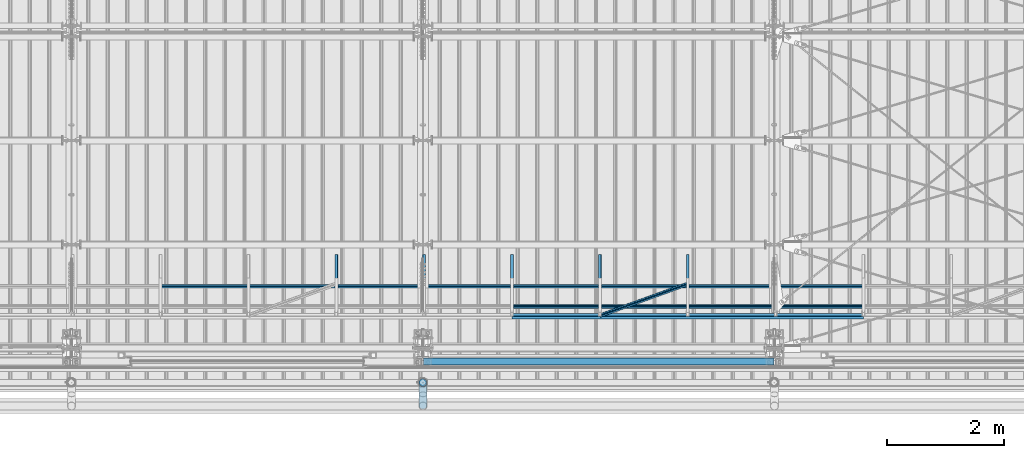
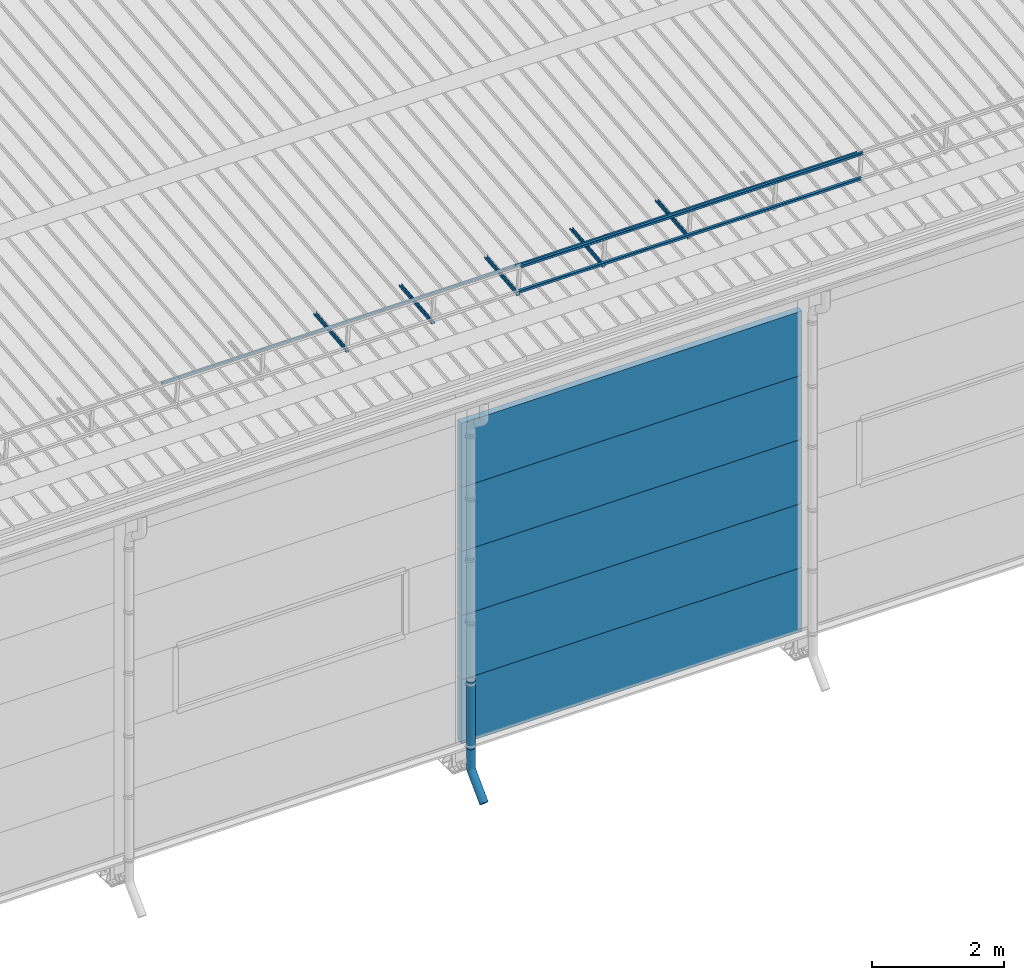
# One storey, part 64 of 709: 18 beams, 18 elements without a shape of their own.
"""IFC4 building model written with IfcOpenShell, lengths in millimetres."""

import ifcopenshell
import ifcopenshell.guid

model = None  # the IFC model being written
_history = None  # IfcOwnerHistory: only IFC2X3 demands one
_inside = {}  # id of a spatial element -> (the spatial element, [elements in it])
_under = {}  # id of a project, library or spatial element -> (it, [spatial elements below it])
_declared = {}  # id of a project -> (the project, [libraries it declares])
_typed = {}  # id of a type object -> (the type object, [elements of that type])
_made_of = {}  # id of a material, layer set ... -> (it, [elements and type objects made of it])


def new_model(schema):
    """Start an empty IFC model of exactly this schema.

    Asked for "IFC4X3", IfcOpenShell would pick the latest addendum, in which some entities
    have other attributes; the version numbers below select the first issue.
    IFC2X3 requires an IfcOwnerHistory on every rooted entity: one is made here for all.
    """
    global model, _history
    if schema == "IFC4X3":
        model = ifcopenshell.file(schema_version=(4, 3, 0, 0))
    else:
        model = ifcopenshell.file(schema=schema)
    _inside.clear()
    _under.clear()
    _declared.clear()
    _typed.clear()
    _made_of.clear()
    _history = None
    if model.schema == "IFC2X3":
        org = make("IfcOrganization", Name="unknown")
        user = make(
            "IfcPersonAndOrganization",
            ThePerson=make("IfcPerson", FamilyName="unknown"),
            TheOrganization=org,
        )
        app = make(
            "IfcApplication",
            ApplicationDeveloper=org,
            Version="unknown",
            ApplicationFullName="unknown",
            ApplicationIdentifier="unknown",
        )
        _history = make(
            "IfcOwnerHistory",
            OwningUser=user,
            OwningApplication=app,
            ChangeAction="ADDED",
            CreationDate=0,
        )
    return model


def make(cls, **values):
    """One entity of the class cls with the attributes given. An attribute that is None is left unset."""
    return model.create_entity(
        cls, **{name: value for name, value in values.items() if value is not None}
    )


def entity(cls, *values):
    """Any entity or typed value of the class cls, its attributes in the order of the schema. None: left unset."""
    e = model.create_entity(cls)
    for i, value in enumerate(values):
        if value is not None:
            e[i] = value
    return e


def rooted(cls, **values):
    """An entity with a GlobalId (a new one), such as an element, a storey or a relation."""
    return make(cls, GlobalId=ifcopenshell.guid.new(), OwnerHistory=_history, **values)


def si_unit(unit_type, name, prefix=None):
    """IfcSIUnit, for example si_unit("LENGTHUNIT", "METRE", prefix="MILLI")."""
    return make("IfcSIUnit", UnitType=unit_type, Prefix=prefix, Name=name)


def assignment(units):
    """IfcUnitAssignment: the units of a project."""
    return None if units is None else make("IfcUnitAssignment", Units=units)


def point(xyz):
    """IfcCartesianPoint."""
    return None if xyz is None else make("IfcCartesianPoint", Coordinates=xyz)


def direction(xyz):
    """IfcDirection."""
    return None if xyz is None else make("IfcDirection", DirectionRatios=xyz)


def frame(location, z_axis=None, x_axis=None):
    """IfcAxis2Placement3D, a coordinate frame: its origin and axes. An axis left out is left unset."""
    return make(
        "IfcAxis2Placement3D",
        Location=point(location),
        Axis=direction(z_axis),
        RefDirection=direction(x_axis),
    )


def origin_with_axes():
    """The frame at (0, 0, 0) with the z axis (0, 0, 1) and the x axis (1, 0, 0) written out."""
    return frame((0.0, 0.0, 0.0), z_axis=(0.0, 0.0, 1.0), x_axis=(1.0, 0.0, 0.0))


def place(relative_to, where):
    """IfcLocalPlacement: puts the frame where relative to a parent placement (None: the world)."""
    return make(
        "IfcLocalPlacement", PlacementRelTo=relative_to, RelativePlacement=where
    )


def context(
    kind, dimensions, precision=None, world=None, true_north=None, identifier=None
):
    """IfcGeometricRepresentationContext, for example the 3D "Model" context."""
    return make(
        "IfcGeometricRepresentationContext",
        ContextIdentifier=identifier,
        ContextType=kind,
        CoordinateSpaceDimension=dimensions,
        Precision=precision,
        WorldCoordinateSystem=world,
        TrueNorth=true_north,
    )


def subcontext(parent, identifier, kind, view, scale=None):
    """IfcGeometricRepresentationSubContext, for example "Body" below "Model"."""
    return make(
        "IfcGeometricRepresentationSubContext",
        ContextIdentifier=identifier,
        ContextType=kind,
        ParentContext=parent,
        TargetScale=scale,
        TargetView=view,
    )


def project(units=None, contexts=None):
    """IfcProject with its units and contexts."""
    return rooted(
        "IfcProject",
        Name="project",
        RepresentationContexts=contexts,
        UnitsInContext=assignment(units),
    )


def spatial(cls, under=None, at=None, **own):
    """A site, building, storey or space (cls), placed at a placement, below another one or the project."""
    s = rooted(cls, ObjectPlacement=at, **own)
    if under is not None:
        _under.setdefault(under.id(), (under, []))[1].append(s)
    return s


def point_list(points):
    """IfcCartesianPointList2D or 3D."""
    cls = (
        "IfcCartesianPointList2D" if len(points[0]) == 2 else "IfcCartesianPointList3D"
    )
    return make(cls, CoordList=points)


def line(*indices):
    """IfcLineIndex: a straight run through numbered points of an indexed curve."""
    return model.create_entity("IfcLineIndex", indices)


def indexed_curve(points, segments=None, self_intersect=None):
    """IfcIndexedPolyCurve: lines and arcs through numbered points (the first is 1)."""
    return make(
        "IfcIndexedPolyCurve",
        Points=point_list(points),
        Segments=segments,
        SelfIntersect=self_intersect,
    )


def outline(outer, holes=None, kind="AREA"):
    """IfcArbitraryClosedProfileDef: a profile drawn as a closed curve; with holes, ...WithVoids."""
    if holes is None:
        return make("IfcArbitraryClosedProfileDef", ProfileType=kind, OuterCurve=outer)
    return make(
        "IfcArbitraryProfileDefWithVoids",
        ProfileType=kind,
        OuterCurve=outer,
        InnerCurves=holes,
    )


def extrude(swept, where, along, depth):
    """IfcExtrudedAreaSolid: the profile swept, set in the frame where, extruded along a direction by depth."""
    return make(
        "IfcExtrudedAreaSolid",
        SweptArea=swept,
        Position=where,
        ExtrudedDirection=direction(along),
        Depth=depth,
    )


def shape(context_of_items, identifier, shape_type, items):
    """IfcShapeRepresentation: the items that make up one representation, for example the "Body"."""
    return make(
        "IfcShapeRepresentation",
        ContextOfItems=context_of_items,
        RepresentationIdentifier=identifier,
        RepresentationType=shape_type,
        Items=items,
    )


def material(Name=None, Category=None):
    """IfcMaterial."""
    return make("IfcMaterial", Name=Name, Category=Category)


def made_of(thing, what):
    """Note that an element or type object is made of a material, layer set ...; save() writes the relation."""
    if what is not None:
        _made_of.setdefault(what.id(), (what, []))[1].append(thing)
    return thing


def element(
    cls,
    number,
    at=None,
    inside=None,
    cuts=None,
    type_object=None,
    material=None,
    context=None,
    identifier="Body",
    shape_type=None,
    held_by="IfcProductDefinitionShape",
    body=None,
    shapes=None,
    **own,
):
    """One element of the class cls, such as IfcWall. Its Tag is "e" and its number.

    at: its placement. inside: the storey or other place that contains it. cuts: it is an
    opening in that element (IfcRelVoidsElement). A single representation is given by context,
    identifier, shape_type and body (its items); several are given by shapes. held_by: the class
    of the entity that holds the representations. save() writes the other relations.
    """
    e = rooted(cls, Tag="e%d" % number, ObjectPlacement=at, **own)
    if body is not None:
        shapes = [shape(context, identifier, shape_type, body)]
    if shapes is not None:
        e.Representation = make(held_by, Representations=shapes)
    if inside is not None:
        _inside.setdefault(inside.id(), (inside, []))[1].append(e)
    if cuts is not None:
        rooted(
            "IfcRelVoidsElement", RelatingBuildingElement=cuts, RelatedOpeningElement=e
        )
    if type_object is not None:
        _typed.setdefault(type_object.id(), (type_object, []))[1].append(e)
    return made_of(e, material)


def aggregate(whole, parts):
    """IfcRelAggregates: a whole, such as a stair, and the parts it consists of."""
    return rooted("IfcRelAggregates", RelatingObject=whole, RelatedObjects=parts)


def save(model, path):
    """Write the relations noted so far, then the file.

    IfcRelAggregates (storeys below a building ...), IfcRelContainedInSpatialStructure (elements
    in a storey), IfcRelDefinesByType, IfcRelAssociatesMaterial and IfcRelDeclares: one each for
    every whole, place, type object, material and project.
    """
    for whole, parts in _under.values():
        aggregate(whole, parts)
    for where, things in _inside.values():
        rooted(
            "IfcRelContainedInSpatialStructure",
            RelatedElements=things,
            RelatingStructure=where,
        )
    for kind, things in _typed.values():
        rooted("IfcRelDefinesByType", RelatedObjects=things, RelatingType=kind)
    for what, things in _made_of.values():
        rooted("IfcRelAssociatesMaterial", RelatedObjects=things, RelatingMaterial=what)
    for by, libraries in _declared.values():
        rooted("IfcRelDeclares", RelatingContext=by, RelatedDefinitions=libraries)
    model.write(path)


model = new_model("IFC4")

# Units and contexts
model_context = context("Model", 3, precision=0.2, world=origin_with_axes(), true_north=direction((0.0, 1.0)))
body_context = subcontext(model_context, "Body", "Model", "MODEL_VIEW")
ifc_project = project(units=[si_unit("LENGTHUNIT", "METRE", prefix="MILLI"), si_unit("AREAUNIT", "SQUARE_METRE"), si_unit("VOLUMEUNIT", "CUBIC_METRE"), si_unit("MASSUNIT", "GRAM", prefix="KILO"), si_unit("TIMEUNIT", "SECOND"), si_unit("PLANEANGLEUNIT", "RADIAN"), si_unit("SOLIDANGLEUNIT", "STERADIAN"), si_unit("THERMODYNAMICTEMPERATUREUNIT", "DEGREE_CELSIUS"), si_unit("LUMINOUSINTENSITYUNIT", "LUMEN")], contexts=[model_context])

# Site, building, storey
site_placement = place(None, origin_with_axes())
site = spatial("IfcSite", under=ifc_project, at=site_placement, CompositionType="ELEMENT")
building_placement = place(site_placement, origin_with_axes())
building = spatial("IfcBuilding", under=site, at=building_placement, Name="Undefined", CompositionType="ELEMENT")
storey_placement = place(building_placement, origin_with_axes())
storey = spatial("IfcBuildingStorey", under=building, at=storey_placement, Name="Undefined", CompositionType="ELEMENT", Elevation=0.0)

# Assembly, beam
assembly_1_placement = place(storey_placement, frame((32520.0, 768.92298, 7577.16191), z_axis=(0.0, -0.099503719, 0.9950371902), x_axis=(0.0, 0.9950371902, 0.099503719)))
assembly_1 = element("IfcElementAssembly", 1, at=assembly_1_placement, inside=storey)
ifc_material_1 = material(Name="Steel_Undefined", Category="STEEL")
beam_1_placement = place(assembly_1_placement, origin_with_axes())
beam_1 = element("IfcBeam", 2, at=beam_1_placement, material=ifc_material_1, ObjectType="601", context=body_context, shape_type="SolidModel", body=[
    extrude(outline(indexed_curve([(-20.0, -25.0), (20.0, -25.0), (20.0, -22.5), (-17.5, -22.5), (-17.5, 22.5), (20.0, 22.5), (20.0, 25.0), (-20.0, 25.0)], segments=[line(1, 2, 3, 4, 5, 6, 7, 8, 1)])), frame((0.0, 0.0, 0.0), z_axis=(-1.0, 0.0, 0.0), x_axis=(0.0, 0.0, 1.0)), (0.0, 0.0, -1.0), 1000.0),
])
aggregate(assembly_1, [beam_1])

assembly_2_placement = place(storey_placement, frame((34020.0, 768.92298, 7577.16191), z_axis=(0.0, -0.099503719, 0.9950371902), x_axis=(0.0, 0.9950371902, 0.099503719)))
assembly_2 = element("IfcElementAssembly", 3, at=assembly_2_placement, inside=storey)
beam_2_placement = place(assembly_2_placement, origin_with_axes())
beam_2 = element("IfcBeam", 4, at=beam_2_placement, material=ifc_material_1, ObjectType="601", context=body_context, shape_type="SolidModel", body=[
    extrude(outline(indexed_curve([(-20.0, -25.0), (20.0, -25.0), (20.0, -22.5), (-17.5, -22.5), (-17.5, 22.5), (20.0, 22.5), (20.0, 25.0), (-20.0, 25.0)], segments=[line(1, 2, 3, 4, 5, 6, 7, 8, 1)])), frame((0.0, 0.0, 0.0), z_axis=(-1.0, 0.0, 0.0), x_axis=(0.0, 0.0, 1.0)), (0.0, 0.0, -1.0), 1000.0),
])
aggregate(assembly_2, [beam_2])

assembly_3_placement = place(storey_placement, frame((29520.0, 1225.80867, 7759.0901), z_axis=(0.0, 0.6332377902, 0.7739572992), x_axis=(1.0, 0.0, 0.0)))
assembly_3 = element("IfcElementAssembly", 5, at=assembly_3_placement, inside=storey)
beam_3_placement = place(assembly_3_placement, origin_with_axes())
beam_3 = element("IfcBeam", 6, at=beam_3_placement, material=ifc_material_1, ObjectType="606", context=body_context, shape_type="SolidModel", body=[
    extrude(outline(indexed_curve([(-20.0, -25.0), (20.0, -25.0), (20.0, -22.5), (-17.5, -22.5), (-17.5, 22.5), (20.0, 22.5), (20.0, 25.0), (-20.0, 25.0)], segments=[line(1, 2, 3, 4, 5, 6, 7, 8, 1)])), frame((0.0, 0.0, 0.0), z_axis=(-1.0, 0.0, 0.0), x_axis=(0.0, 0.0, 1.0)), (0.0, 0.0, -1.0), 6000.0),
])
aggregate(assembly_3, [beam_3])

assembly_4_placement = place(storey_placement, frame((35520.0, 768.92298, 7577.16191), z_axis=(0.0, -0.099503719, 0.9950371902), x_axis=(0.0, 0.9950371902, 0.099503719)))
assembly_4 = element("IfcElementAssembly", 7, at=assembly_4_placement, inside=storey)
beam_4_placement = place(assembly_4_placement, origin_with_axes())
beam_4 = element("IfcBeam", 8, at=beam_4_placement, material=ifc_material_1, ObjectType="601", context=body_context, shape_type="SolidModel", body=[
    extrude(outline(indexed_curve([(-20.0, -25.0), (20.0, -25.0), (20.0, -22.5), (-17.5, -22.5), (-17.5, 22.5), (20.0, 22.5), (20.0, 25.0), (-20.0, 25.0)], segments=[line(1, 2, 3, 4, 5, 6, 7, 8, 1)])), frame((0.0, 0.0, 0.0), z_axis=(-1.0, 0.0, 0.0), x_axis=(0.0, 0.0, 1.0)), (0.0, 0.0, -1.0), 1000.0),
])
aggregate(assembly_4, [beam_4])

assembly_5_placement = place(storey_placement, frame((37020.0, 768.92298, 7577.16191), z_axis=(0.0, -0.099503719, 0.9950371902), x_axis=(0.0, 0.9950371902, 0.099503719)))
assembly_5 = element("IfcElementAssembly", 9, at=assembly_5_placement, inside=storey)
beam_5_placement = place(assembly_5_placement, origin_with_axes())
beam_5 = element("IfcBeam", 10, at=beam_5_placement, material=ifc_material_1, ObjectType="601", context=body_context, shape_type="SolidModel", body=[
    extrude(outline(indexed_curve([(-20.0, -25.0), (20.0, -25.0), (20.0, -22.5), (-17.5, -22.5), (-17.5, 22.5), (20.0, 22.5), (20.0, 25.0), (-20.0, 25.0)], segments=[line(1, 2, 3, 4, 5, 6, 7, 8, 1)])), frame((0.0, 0.0, 0.0), z_axis=(-1.0, 0.0, 0.0), x_axis=(0.0, 0.0, 1.0)), (0.0, 0.0, -1.0), 1000.0),
])
aggregate(assembly_5, [beam_5])

assembly_6_placement = place(storey_placement, frame((38520.0, 768.92298, 7577.16191), z_axis=(0.0, -0.099503719, 0.9950371902), x_axis=(0.0, 0.9950371902, 0.099503719)))
assembly_6 = element("IfcElementAssembly", 11, at=assembly_6_placement, inside=storey)
beam_6_placement = place(assembly_6_placement, origin_with_axes())
beam_6 = element("IfcBeam", 12, at=beam_6_placement, material=ifc_material_1, ObjectType="601", context=body_context, shape_type="SolidModel", body=[
    extrude(outline(indexed_curve([(-20.0, -25.0), (20.0, -25.0), (20.0, -22.5), (-17.5, -22.5), (-17.5, 22.5), (20.0, 22.5), (20.0, 25.0), (-20.0, 25.0)], segments=[line(1, 2, 3, 4, 5, 6, 7, 8, 1)])), frame((0.0, 0.0, 0.0), z_axis=(-1.0, 0.0, 0.0), x_axis=(0.0, 0.0, 1.0)), (0.0, 0.0, -1.0), 1000.0),
])
aggregate(assembly_6, [beam_6])

assembly_7_placement = place(storey_placement, frame((35520.0, 691.31008, 8152.29341), z_axis=(0.0, -0.9950371902, -0.099503719), x_axis=(1.0, 0.0, 0.0)))
assembly_7 = element("IfcElementAssembly", 13, at=assembly_7_placement, inside=storey)
beam_7_placement = place(assembly_7_placement, origin_with_axes())
beam_7 = element("IfcBeam", 14, at=beam_7_placement, material=ifc_material_1, ObjectType="606", context=body_context, shape_type="SolidModel", body=[
    extrude(outline(indexed_curve([(-20.0, -25.0), (20.0, -25.0), (20.0, -22.5), (-17.5, -22.5), (-17.5, 22.5), (20.0, 22.5), (20.0, 25.0), (-20.0, 25.0)], segments=[line(1, 2, 3, 4, 5, 6, 7, 8, 1)])), frame((0.0, 0.0, 0.0), z_axis=(-1.0, 0.0, 0.0), x_axis=(0.0, 0.0, 1.0)), (0.0, 0.0, -1.0), 6000.0),
])
aggregate(assembly_7, [beam_7])

assembly_8_placement = place(storey_placement, frame((35520.0, 741.06194, 7654.77481), z_axis=(0.0, -0.9950371902, -0.099503719), x_axis=(1.0, 0.0, 0.0)))
assembly_8 = element("IfcElementAssembly", 15, at=assembly_8_placement, inside=storey)
beam_8_placement = place(assembly_8_placement, origin_with_axes())
beam_8 = element("IfcBeam", 16, at=beam_8_placement, material=ifc_material_1, ObjectType="606", context=body_context, shape_type="SolidModel", body=[
    extrude(outline(indexed_curve([(-20.0, -25.0), (20.0, -25.0), (20.0, -22.5), (-17.5, -22.5), (-17.5, 22.5), (20.0, 22.5), (20.0, 25.0), (-20.0, 25.0)], segments=[line(1, 2, 3, 4, 5, 6, 7, 8, 1)])), frame((0.0, 0.0, 0.0), z_axis=(-1.0, 0.0, 0.0), x_axis=(0.0, 0.0, 1.0)), (0.0, 0.0, -1.0), 6000.0),
])
aggregate(assembly_8, [beam_8])

assembly_9_placement = place(storey_placement, frame((35520.0, 878.66704, 8043.11507), z_axis=(0.0, 0.6332377902, 0.7739572992), x_axis=(1.0, 0.0, 0.0)))
assembly_9 = element("IfcElementAssembly", 17, at=assembly_9_placement, inside=storey)
beam_9_placement = place(assembly_9_placement, origin_with_axes())
beam_9 = element("IfcBeam", 18, at=beam_9_placement, material=ifc_material_1, ObjectType="606", context=body_context, shape_type="SolidModel", body=[
    extrude(outline(indexed_curve([(-20.0, -25.0), (20.0, -25.0), (20.0, -22.5), (-17.5, -22.5), (-17.5, 22.5), (20.0, 22.5), (20.0, 25.0), (-20.0, 25.0)], segments=[line(1, 2, 3, 4, 5, 6, 7, 8, 1)])), frame((0.0, 0.0, 0.0), z_axis=(-1.0, 0.0, 0.0), x_axis=(0.0, 0.0, 1.0)), (0.0, 0.0, -1.0), 6000.0),
])
aggregate(assembly_9, [beam_9])

assembly_10_placement = place(storey_placement, frame((35520.0, 1225.80867, 7759.0901), z_axis=(0.0, 0.6332377902, 0.7739572992), x_axis=(1.0, 0.0, 0.0)))
assembly_10 = element("IfcElementAssembly", 19, at=assembly_10_placement, inside=storey)
beam_10_placement = place(assembly_10_placement, origin_with_axes())
beam_10 = element("IfcBeam", 20, at=beam_10_placement, material=ifc_material_1, ObjectType="606", context=body_context, shape_type="SolidModel", body=[
    extrude(outline(indexed_curve([(-20.0, -25.0), (20.0, -25.0), (20.0, -22.5), (-17.5, -22.5), (-17.5, 22.5), (20.0, 22.5), (20.0, 25.0), (-20.0, 25.0)], segments=[line(1, 2, 3, 4, 5, 6, 7, 8, 1)])), frame((0.0, 0.0, 0.0), z_axis=(-1.0, 0.0, 0.0), x_axis=(0.0, 0.0, 1.0)), (0.0, 0.0, -1.0), 6000.0),
])
aggregate(assembly_10, [beam_10])

assembly_11_placement = place(storey_placement, frame((37020.0, 723.87558, 8169.76263), z_axis=(0.0, 0.6332377902, 0.7739572992), x_axis=(0.9061831398, 0.3272952929, -0.2677870579)))
assembly_11 = element("IfcElementAssembly", 21, at=assembly_11_placement, inside=storey)
beam_11_placement = place(assembly_11_placement, origin_with_axes())
beam_11 = element("IfcBeam", 22, at=beam_11_placement, material=ifc_material_1, ObjectType="605", context=body_context, shape_type="SolidModel", body=[
    extrude(outline(indexed_curve([(-20.0, -25.0), (20.0, -25.0), (20.0, -22.5), (-17.5, -22.5), (-17.5, 22.5), (20.0, 22.5), (20.0, 25.0), (-20.0, 25.0)], segments=[line(1, 2, 3, 4, 5, 6, 7, 8, 1)])), frame((0.0, 0.0, 0.0), z_axis=(-1.0, 0.0, 0.0), x_axis=(0.0, 0.0, 1.0)), (0.0, 0.0, -1.0), 1655.29454),
])
aggregate(assembly_11, [beam_11])

assembly_12_placement = place(storey_placement, frame((34010.0, -60.0, 895.0), z_axis=(0.0, 0.0, -1.0), x_axis=(1.0, 0.0, 0.0)))
assembly_12 = element("IfcElementAssembly", 23, at=assembly_12_placement, inside=storey)
ifc_material_2 = material(Name="Insulation", Category="Insulation")
beam_12_placement = place(assembly_12_placement, origin_with_axes())
beam_12 = element("IfcBeam", 24, at=beam_12_placement, material=ifc_material_2, ObjectType="P-107", context=body_context, shape_type="SolidModel", body=[
    extrude(outline(indexed_curve([(-595.0, -60.0), (595.0, -60.0), (595.0, 60.0), (-595.0, 60.0)], segments=[line(1, 2, 3, 4, 1)])), frame((0.0, 0.0, 0.0), z_axis=(-1.0, 0.0, 0.0), x_axis=(0.0, 0.0, 1.0)), (0.0, 0.0, -1.0), 5980.0),
])
aggregate(assembly_12, [beam_12])

assembly_13_placement = place(storey_placement, frame((34010.0, -60.0, 2085.0), z_axis=(0.0, 0.0, -1.0), x_axis=(1.0, 0.0, 0.0)))
assembly_13 = element("IfcElementAssembly", 25, at=assembly_13_placement, inside=storey)
beam_13_placement = place(assembly_13_placement, origin_with_axes())
beam_13 = element("IfcBeam", 26, at=beam_13_placement, material=ifc_material_2, ObjectType="P-107", context=body_context, shape_type="SolidModel", body=[
    extrude(outline(indexed_curve([(-595.0, -60.0), (595.0, -60.0), (595.0, 60.0), (-595.0, 60.0)], segments=[line(1, 2, 3, 4, 1)])), frame((0.0, 0.0, 0.0), z_axis=(-1.0, 0.0, 0.0), x_axis=(0.0, 0.0, 1.0)), (0.0, 0.0, -1.0), 5980.0),
])
aggregate(assembly_13, [beam_13])

assembly_14_placement = place(storey_placement, frame((34010.0, -60.0, 3275.0), z_axis=(0.0, 0.0, -1.0), x_axis=(1.0, 0.0, 0.0)))
assembly_14 = element("IfcElementAssembly", 27, at=assembly_14_placement, inside=storey)
beam_14_placement = place(assembly_14_placement, origin_with_axes())
beam_14 = element("IfcBeam", 28, at=beam_14_placement, material=ifc_material_2, ObjectType="P-107", context=body_context, shape_type="SolidModel", body=[
    extrude(outline(indexed_curve([(-595.0, -60.0), (595.0, -60.0), (595.0, 60.0), (-595.0, 60.0)], segments=[line(1, 2, 3, 4, 1)])), frame((0.0, 0.0, 0.0), z_axis=(-1.0, 0.0, 0.0), x_axis=(0.0, 0.0, 1.0)), (0.0, 0.0, -1.0), 5980.0),
])
aggregate(assembly_14, [beam_14])

assembly_15_placement = place(storey_placement, frame((34010.0, -60.0, 4465.0), z_axis=(0.0, 0.0, -1.0), x_axis=(1.0, 0.0, 0.0)))
assembly_15 = element("IfcElementAssembly", 29, at=assembly_15_placement, inside=storey)
beam_15_placement = place(assembly_15_placement, origin_with_axes())
beam_15 = element("IfcBeam", 30, at=beam_15_placement, material=ifc_material_2, ObjectType="P-107", context=body_context, shape_type="SolidModel", body=[
    extrude(outline(indexed_curve([(-595.0, -60.0), (595.0, -60.0), (595.0, 60.0), (-595.0, 60.0)], segments=[line(1, 2, 3, 4, 1)])), frame((0.0, 0.0, 0.0), z_axis=(-1.0, 0.0, 0.0), x_axis=(0.0, 0.0, 1.0)), (0.0, 0.0, -1.0), 5980.0),
])
aggregate(assembly_15, [beam_15])

assembly_16_placement = place(storey_placement, frame((34010.0, -60.0, 5655.0), z_axis=(0.0, 0.0, -1.0), x_axis=(1.0, 0.0, 0.0)))
assembly_16 = element("IfcElementAssembly", 31, at=assembly_16_placement, inside=storey)
beam_16_placement = place(assembly_16_placement, origin_with_axes())
beam_16 = element("IfcBeam", 32, at=beam_16_placement, material=ifc_material_2, ObjectType="P-107", context=body_context, shape_type="SolidModel", body=[
    extrude(outline(indexed_curve([(-595.0, -60.0), (595.0, -60.0), (595.0, 60.0), (-595.0, 60.0)], segments=[line(1, 2, 3, 4, 1)])), frame((0.0, 0.0, 0.0), z_axis=(-1.0, 0.0, 0.0), x_axis=(0.0, 0.0, 1.0)), (0.0, 0.0, -1.0), 5980.0),
])
aggregate(assembly_16, [beam_16])

assembly_17_placement = place(storey_placement, frame((34000.0, -420.0, 1676.92297), z_axis=(0.0, 1.0, 0.0), x_axis=(0.0, 0.0, -1.0)))
assembly_17 = element("IfcElementAssembly", 33, at=assembly_17_placement, inside=storey)
beam_17_placement = place(assembly_17_placement, origin_with_axes())
beam_17 = element("IfcBeam", 34, at=beam_17_placement, material=ifc_material_1, ObjectType="614", context=body_context, shape_type="SolidModel", body=[
    extrude(outline(indexed_curve([(70.0, 0.0), (69.61653, 7.31699), (68.47033, 14.55382), (66.57396, 21.63119), (63.94818, 28.47157), (60.62178, 35.0), (56.63119, 41.14497), (52.02014, 46.83914), (46.83914, 52.02014), (41.14497, 56.63119), (35.0, 60.62178), (28.47157, 63.94818), (21.63119, 66.57396), (14.55382, 68.47033), (7.31699, 69.61653), (0.0, 70.0), (-7.31699, 69.61653), (-14.55382, 68.47033), (-21.63119, 66.57396), (-28.47157, 63.94818), (-35.0, 60.62178), (-41.14497, 56.63119), (-46.83914, 52.02014), (-52.02014, 46.83914), (-56.63119, 41.14497), (-60.62178, 35.0), (-63.94818, 28.47157), (-66.57396, 21.63119), (-68.47033, 14.55382), (-69.61653, 7.31699), (-70.0, 0.0), (-69.61653, -7.31699), (-68.47033, -14.55382), (-66.57396, -21.63119), (-63.94818, -28.47157), (-60.62178, -35.0), (-56.63119, -41.14497), (-52.02014, -46.83914), (-46.83914, -52.02014), (-41.14497, -56.63119), (-35.0, -60.62178), (-28.47157, -63.94818), (-21.63119, -66.57396), (-14.55382, -68.47033), (-7.31699, -69.61653), (0.0, -70.0), (7.31699, -69.61653), (14.55382, -68.47033), (21.63119, -66.57396), (28.47157, -63.94818), (35.0, -60.62178), (41.14497, -56.63119), (46.83914, -52.02014), (52.02014, -46.83914), (56.63119, -41.14497), (60.62178, -35.0), (63.94818, -28.47157), (66.57396, -21.63119), (68.47033, -14.55382), (69.61653, -7.31699)], segments=[line(1, 2, 3, 4, 5, 6, 7, 8, 9, 10, 11, 12, 13, 14, 15, 16, 17, 18, 19, 20, 21, 22, 23, 24, 25, 26, 27, 28, 29, 30, 31, 32, 33, 34, 35, 36, 37, 38, 39, 40, 41, 42, 43, 44, 45, 46, 47, 48, 49, 50, 51, 52, 53, 54, 55, 56, 57, 58, 59, 60, 1)]), holes=[indexed_curve([(65.0, 0.0), (64.64392, -6.79435), (63.57959, -13.51426), (61.81867, -20.0861), (59.38045, -26.43788), (56.29165, -32.5), (52.5861, -38.20604), (48.30441, -43.49349), (43.49349, -48.30441), (38.20604, -52.5861), (32.5, -56.29165), (26.43788, -59.38045), (20.0861, -61.81867), (13.51426, -63.57959), (6.79435, -64.64392), (0.0, -65.0), (-6.79435, -64.64392), (-13.51426, -63.57959), (-20.0861, -61.81867), (-26.43788, -59.38045), (-32.5, -56.29165), (-38.20604, -52.5861), (-43.49349, -48.30441), (-48.30441, -43.49349), (-52.5861, -38.20604), (-56.29165, -32.5), (-59.38045, -26.43788), (-61.81867, -20.0861), (-63.57959, -13.51426), (-64.64392, -6.79435), (-65.0, 0.0), (-64.64392, 6.79435), (-63.57959, 13.51426), (-61.81867, 20.0861), (-59.38045, 26.43788), (-56.29165, 32.5), (-52.5861, 38.20604), (-48.30441, 43.49349), (-43.49349, 48.30441), (-38.20604, 52.5861), (-32.5, 56.29165), (-26.43788, 59.38045), (-20.0861, 61.81867), (-13.51426, 63.57959), (-6.79435, 64.64392), (0.0, 65.0), (6.79435, 64.64392), (13.51426, 63.57959), (20.0861, 61.81867), (26.43788, 59.38045), (32.5, 56.29165), (38.20604, 52.5861), (43.49349, 48.30441), (48.30441, 43.49349), (52.5861, 38.20604), (56.29165, 32.5), (59.38045, 26.43788), (61.81867, 20.0861), (63.57959, 13.51426), (64.64392, 6.79435)], segments=[line(1, 2, 3, 4, 5, 6, 7, 8, 9, 10, 11, 12, 13, 14, 15, 16, 17, 18, 19, 20, 21, 22, 23, 24, 25, 26, 27, 28, 29, 30, 31, 32, 33, 34, 35, 36, 37, 38, 39, 40, 41, 42, 43, 44, 45, 46, 47, 48, 49, 50, 51, 52, 53, 54, 55, 56, 57, 58, 59, 60, 1)])]), frame((0.0, 0.0, 0.0), z_axis=(-1.0, 0.0, 0.0), x_axis=(0.0, 0.0, 1.0)), (0.0, 0.0, -1.0), 1250.0),
])
aggregate(assembly_17, [beam_17])

assembly_18_placement = place(storey_placement, frame((34000.0, -420.0, 526.92297), z_axis=(-1.0, 0.0, 0.0), x_axis=(0.0, 0.0, -1.0)))
assembly_18 = element("IfcElementAssembly", 35, at=assembly_18_placement, inside=storey)
beam_18_placement = place(assembly_18_placement, origin_with_axes())
beam_18 = element("IfcBeam", 36, at=beam_18_placement, material=ifc_material_1, ObjectType="617", context=body_context, shape_type="SolidModel", body=[
    entity("IfcSweptDiskSolid", entity("IfcIndexedPolyCurve", entity("IfcCartesianPointList3D", [[0.0, 0.0, 0.0], [448.2233, 0.0, 0.0], [496.05873, 9.51506, 0.0], [536.61165, 36.61165, 0.0], [900.0, 400.0, 0.0]]), [entity("IfcLineIndex", [1, 2]), entity("IfcArcIndex", [2, 3, 4]), entity("IfcLineIndex", [4, 5])]), 70.0, 65.0),
])
aggregate(assembly_18, [beam_18])

save(model, "model.ifc")
